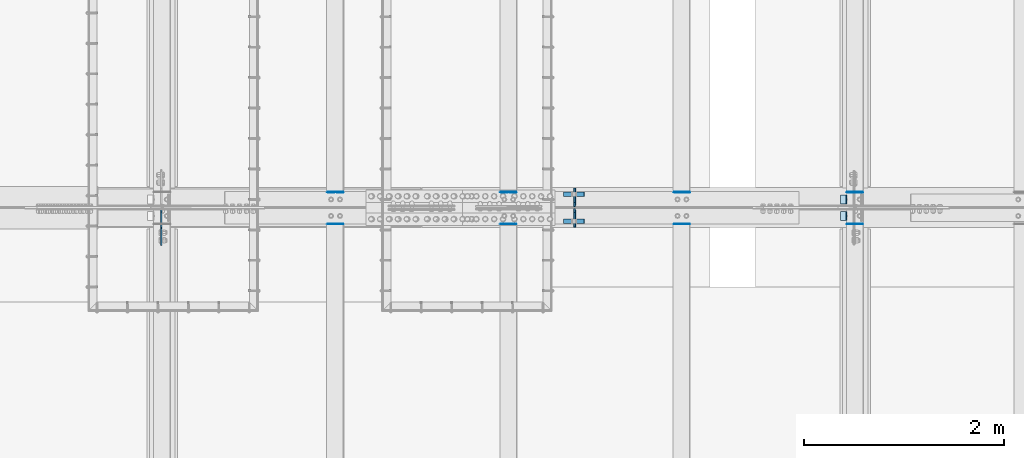
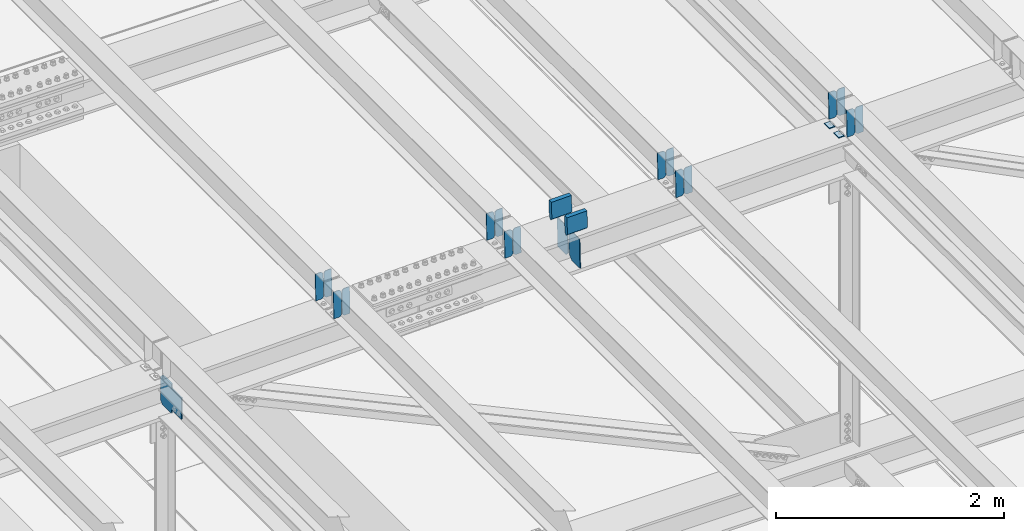
# One storey, part 3435 of 3843: 23 plates, 10 elements without a shape of their own.
"""IFC2X3 building model written with IfcOpenShell, lengths in millimetres."""

from ifc_helpers import new_model, si_unit, frame, origin_with_axes, place, context, subcontext, project, spatial, faceted_brep, material, type_object, element, aggregate, save


model = new_model("IFC2X3")

# Units and contexts
model_context = context("Model", 3, precision=1e-05, world=origin_with_axes())
body_context = subcontext(model_context, "Body", "Model", "MODEL_VIEW")
ifc_project = project(units=[si_unit("LENGTHUNIT", "METRE", prefix="MILLI"), si_unit("AREAUNIT", "SQUARE_METRE"), si_unit("VOLUMEUNIT", "CUBIC_METRE"), si_unit("MASSUNIT", "GRAM", prefix="KILO"), si_unit("TIMEUNIT", "SECOND"), si_unit("PLANEANGLEUNIT", "RADIAN"), si_unit("SOLIDANGLEUNIT", "STERADIAN"), si_unit("THERMODYNAMICTEMPERATUREUNIT", "DEGREE_CELSIUS"), si_unit("LUMINOUSINTENSITYUNIT", "LUMEN")], contexts=[model_context])

# Site, building, storey
site_placement = place(None, origin_with_axes())
site = spatial("IfcSite", under=ifc_project, at=site_placement, CompositionType="ELEMENT")
building_placement = place(site_placement, origin_with_axes())
building = spatial("IfcBuilding", under=site, at=building_placement, Name="Undefined", CompositionType="ELEMENT")
storey_placement = place(building_placement, origin_with_axes())
storey = spatial("IfcBuildingStorey", under=building, at=storey_placement, Name="Undefined", CompositionType="ELEMENT", Elevation=0.0)

# Assembly, plates
assembly_1_placement = place(storey_placement, origin_with_axes())
assembly_1 = element("IfcElementAssembly", 1, at=assembly_1_placement, inside=storey, Name="BEAM", AssemblyPlace="NOTDEFINED", PredefinedType="RIGID_FRAME")
ifc_material = material(Name="STEEL/A572-50")
plate_type_1 = type_object("IfcPlateType", PredefinedType="NOTDEFINED")
plate_1_placement = place(assembly_1_placement, frame((56013.0964783468, 67427.0111412027, 45923.0045844467), z_axis=(-0.0211520975519379, 0.00155378299993753, 0.999775061965211), x_axis=(-0.999776269354785, -3.22879999736168e-05, -0.0211520730074938)))
plate_1 = element("IfcPlate", 2, at=plate_1_placement, type_object=plate_type_1, material=ifc_material, Name="PLATE", context=body_context, shape_type="Brep", body=[
    faceted_brep([(0.0, -3.17499999999927, 0.0), (6.83940015733242e-10, -3.17499999996653, 288.924999998613), (6.54836185276508e-10, 3.17500000001746, 288.924999998591), (0.0, 3.17499999999927, 0.0), (60.3250007643655, -3.17500000017753, 288.924999998606), (60.3250007643219, 3.17499999979918, 288.924999998584), (79.3750000013097, -3.17500000025029, 269.875000761494), (79.375000001266, 3.17499999972642, 269.875000761487), (79.375000000713, -3.17500000026484, 19.0499992370605), (79.3750000006985, 3.17499999971187, 19.0499992370533), (60.325000763667, -3.17500000020664, -1.45519152283669e-11), (60.3250007636234, 3.17499999977736, -3.63797880709171e-11)], [[[0, 1, 2, 3]], [[1, 4, 5, 2]], [[4, 6, 7, 5]], [[6, 8, 9, 7]], [[8, 10, 11, 9]], [[10, 0, 3, 11]], [[5, 7, 9, 11, 3, 2]], [[10, 8, 6, 4, 1, 0]]]),
])
plate_2_placement = place(assembly_1_placement, frame((55927.3906576571, 67427.008323154, 45921.1913230356), z_axis=(-0.0211520975519379, 0.00155378299993753, 0.999775061965211), x_axis=(-0.999776269354785, -3.22879999736168e-05, -0.0211520730074938)))
plate_2 = element("IfcPlate", 3, at=plate_2_placement, type_object=plate_type_1, material=ifc_material, Name="PLATE", context=body_context, shape_type="Brep", body=[
    faceted_brep([(4.36557456851006e-11, -3.17499999998836, 19.0499992370969), (6.11180439591408e-10, -3.17499999996653, 269.875000761516), (5.96628524363041e-10, 3.17500000001746, 269.875000761502), (1.45519152283669e-11, 3.17499999998836, 19.0499992370824), (19.0499992376572, -3.17500000003201, 288.924999998606), (19.0499992376281, 3.1749999999447, 288.924999998584), (79.3750000013242, -3.17500000025029, 288.924999998591), (79.3750000013097, 3.1749999997337, 288.92499999857), (79.3750000006548, -3.17500000026484, -2.18278728425503e-11), (79.3750000006403, 3.17499999969732, -2.91038304567337e-11), (19.0499992370023, -3.17500000005384, 0.0), (19.0499992369587, 3.17499999992287, -1.45519152283669e-11)], [[[0, 1, 2, 3]], [[1, 4, 5, 2]], [[4, 6, 7, 5]], [[6, 8, 9, 7]], [[8, 10, 11, 9]], [[10, 0, 3, 11]], [[5, 7, 9, 11, 3, 2]], [[10, 8, 6, 4, 1, 0]]]),
])

assembly_2_placement = place(storey_placement, origin_with_axes())
assembly_2 = element("IfcElementAssembly", 4, at=assembly_2_placement, inside=storey, Name="BEAM", AssemblyPlace="NOTDEFINED", PredefinedType="RIGID_FRAME")
plate_3_placement = place(assembly_2_placement, frame((56013.0964783463, 67109.8915915396, 45923.2909467294), z_axis=(-0.0211520978350237, 0.000279663000066649, 0.999776230236438), x_axis=(-0.999776269348334, -6.33400000515396e-06, -0.0211520970073616)))
plate_3 = element("IfcPlate", 5, at=plate_3_placement, type_object=plate_type_1, material=ifc_material, Name="PLATE", context=body_context, shape_type="Brep", body=[
    faceted_brep([(0.0, -3.17499999999927, 0.0), (6.83940015733242e-10, -3.17499999996653, 288.924999998613), (6.54836185276508e-10, 3.17500000001746, 288.924999998591), (0.0, 3.17499999999927, 0.0), (60.3250007643655, -3.17500000017753, 288.924999998606), (60.3250007643219, 3.17499999979918, 288.924999998584), (79.3750000013097, -3.17500000025029, 269.875000761494), (79.375000001266, 3.17499999972642, 269.875000761487), (79.375000000713, -3.17500000026484, 19.0499992370605), (79.3750000006985, 3.17499999971187, 19.0499992370533), (60.325000763667, -3.17500000020664, -1.45519152283669e-11), (60.3250007636234, 3.17499999977736, -3.63797880709171e-11)], [[[0, 1, 2, 3]], [[1, 4, 5, 2]], [[4, 6, 7, 5]], [[6, 8, 9, 7]], [[8, 10, 11, 9]], [[10, 0, 3, 11]], [[5, 7, 9, 11, 3, 2]], [[10, 8, 6, 4, 1, 0]]]),
])
plate_4_placement = place(assembly_2_placement, frame((55927.3906576567, 67109.8910843224, 45921.4776831989), z_axis=(-0.0211520978350237, 0.000279663000066649, 0.999776230236438), x_axis=(-0.999776269348334, -6.33400000515396e-06, -0.0211520970073616)))
plate_4 = element("IfcPlate", 6, at=plate_4_placement, type_object=plate_type_1, material=ifc_material, Name="PLATE", context=body_context, shape_type="Brep", body=[
    faceted_brep([(4.36557456851006e-11, -3.17499999998836, 19.0499992370969), (6.11180439591408e-10, -3.17499999996653, 269.875000761516), (5.96628524363041e-10, 3.17500000001746, 269.875000761502), (1.45519152283669e-11, 3.17499999998836, 19.0499992370824), (19.0499992376572, -3.17500000003201, 288.924999998606), (19.0499992376281, 3.1749999999447, 288.924999998584), (79.3750000013242, -3.17500000025029, 288.924999998591), (79.3750000013097, 3.1749999997337, 288.92499999857), (79.3750000006548, -3.17500000026484, -2.18278728425503e-11), (79.3750000006403, 3.17499999969732, -2.91038304567337e-11), (19.0499992370023, -3.17500000005384, 0.0), (19.0499992369587, 3.17499999992287, -1.45519152283669e-11)], [[[0, 1, 2, 3]], [[1, 4, 5, 2]], [[4, 6, 7, 5]], [[6, 8, 9, 7]], [[8, 10, 11, 9]], [[10, 0, 3, 11]], [[5, 7, 9, 11, 3, 2]], [[10, 8, 6, 4, 1, 0]]]),
])

assembly_3_placement = place(storey_placement, origin_with_axes())
assembly_3 = element("IfcElementAssembly", 7, at=assembly_3_placement, inside=storey, Name="BEAM", AssemblyPlace="NOTDEFINED", PredefinedType="RIGID_FRAME")
plate_5_placement = place(assembly_3_placement, frame((54279.5464783245, 67427.0411486902, 45881.8611801861), z_axis=(-0.0211520983557567, 0.00145334399999411, 0.999775212998585), x_axis=(-0.999776269338764, -3.00889999762259e-05, -0.021152077007147)))
plate_5 = element("IfcPlate", 8, at=plate_5_placement, type_object=plate_type_1, material=ifc_material, Name="PLATE", context=body_context, shape_type="Brep", body=[
    faceted_brep([(0.0, -3.17499999999927, 0.0), (6.83940015733242e-10, -3.17499999996653, 288.924999998613), (6.54836185276508e-10, 3.17500000001746, 288.924999998591), (0.0, 3.17499999999927, 0.0), (60.3250007643655, -3.17500000017753, 288.924999998606), (60.3250007643219, 3.17499999979918, 288.924999998584), (79.3750000013097, -3.17500000025029, 269.875000761494), (79.375000001266, 3.17499999972642, 269.875000761487), (79.375000000713, -3.17500000026484, 19.0499992370605), (79.3750000006985, 3.17499999971187, 19.0499992370533), (60.325000763667, -3.17500000020664, -1.45519152283669e-11), (60.3250007636234, 3.17499999977736, -3.63797880709171e-11)], [[[0, 1, 2, 3]], [[1, 4, 5, 2]], [[4, 6, 7, 5]], [[6, 8, 9, 7]], [[8, 10, 11, 9]], [[10, 0, 3, 11]], [[5, 7, 9, 11, 3, 2]], [[10, 8, 6, 4, 1, 0]]]),
])
plate_6_placement = place(assembly_3_placement, frame((54193.8406576349, 67427.0385128048, 45880.0479185013), z_axis=(-0.0211520983557567, 0.00145334399999411, 0.999775212998585), x_axis=(-0.999776269338764, -3.00889999762259e-05, -0.021152077007147)))
plate_6 = element("IfcPlate", 9, at=plate_6_placement, type_object=plate_type_1, material=ifc_material, Name="PLATE", context=body_context, shape_type="Brep", body=[
    faceted_brep([(4.36557456851006e-11, -3.17499999998836, 19.0499992370969), (6.11180439591408e-10, -3.17499999996653, 269.875000761516), (5.96628524363041e-10, 3.17500000001746, 269.875000761502), (1.45519152283669e-11, 3.17499999998836, 19.0499992370824), (19.0499992376572, -3.17500000003201, 288.924999998606), (19.0499992376281, 3.1749999999447, 288.924999998584), (79.3750000013242, -3.17500000025029, 288.924999998591), (79.3750000013097, 3.1749999997337, 288.92499999857), (79.3750000006548, -3.17500000026484, -2.18278728425503e-11), (79.3750000006403, 3.17499999969732, -2.91038304567337e-11), (19.0499992370023, -3.17500000005384, 0.0), (19.0499992369587, 3.17499999992287, -1.45519152283669e-11)], [[[0, 1, 2, 3]], [[1, 4, 5, 2]], [[4, 6, 7, 5]], [[6, 8, 9, 7]], [[8, 10, 11, 9]], [[10, 0, 3, 11]], [[5, 7, 9, 11, 3, 2]], [[10, 8, 6, 4, 1, 0]]]),
])
aggregate(assembly_3, [plate_5, plate_6])

assembly_4_placement = place(storey_placement, origin_with_axes())
assembly_4 = element("IfcElementAssembly", 10, at=assembly_4_placement, inside=storey, Name="BEAM", AssemblyPlace="NOTDEFINED", PredefinedType="RIGID_FRAME")
plate_7_placement = place(assembly_4_placement, frame((54279.5464782984, 67109.8990383334, 45882.1279630658), z_axis=(-0.0211520976937244, 0.000254690999980084, 0.999776236912865), x_axis=(-0.999776269348334, -6.33400000515396e-06, -0.0211520970073616)))
plate_7 = element("IfcPlate", 11, at=plate_7_placement, type_object=plate_type_1, material=ifc_material, Name="PLATE", context=body_context, shape_type="Brep", body=[
    faceted_brep([(0.0, -3.17499999999927, 0.0), (6.83940015733242e-10, -3.17499999996653, 288.924999998613), (6.54836185276508e-10, 3.17500000001746, 288.924999998591), (0.0, 3.17499999999927, 0.0), (60.3250007643655, -3.17500000017753, 288.924999998606), (60.3250007643219, 3.17499999979918, 288.924999998584), (79.3750000013097, -3.17500000025029, 269.875000761494), (79.375000001266, 3.17499999972642, 269.875000761487), (79.375000000713, -3.17500000026484, 19.0499992370605), (79.3750000006985, 3.17499999971187, 19.0499992370533), (60.325000763667, -3.17500000020664, -1.45519152283669e-11), (60.3250007636234, 3.17499999977736, -3.63797880709171e-11)], [[[0, 1, 2, 3]], [[1, 4, 5, 2]], [[4, 6, 7, 5]], [[6, 8, 9, 7]], [[8, 10, 11, 9]], [[10, 0, 3, 11]], [[5, 7, 9, 11, 3, 2]], [[10, 8, 6, 4, 1, 0]]]),
])
plate_8_placement = place(assembly_4_placement, frame((54193.8406576091, 67109.8985764075, 45880.3146995236), z_axis=(-0.0211520976937244, 0.000254690999980084, 0.999776236912865), x_axis=(-0.999776269348334, -6.33400000515396e-06, -0.0211520970073616)))
plate_8 = element("IfcPlate", 12, at=plate_8_placement, type_object=plate_type_1, material=ifc_material, Name="PLATE", context=body_context, shape_type="Brep", body=[
    faceted_brep([(4.36557456851006e-11, -3.17499999998836, 19.0499992370969), (6.11180439591408e-10, -3.17499999996653, 269.875000761516), (5.96628524363041e-10, 3.17500000001746, 269.875000761502), (1.45519152283669e-11, 3.17499999998836, 19.0499992370824), (19.0499992376572, -3.17500000003201, 288.924999998606), (19.0499992376281, 3.1749999999447, 288.924999998584), (79.3750000013242, -3.17500000025029, 288.924999998591), (79.3750000013097, 3.1749999997337, 288.92499999857), (79.3750000006548, -3.17500000026484, -2.18278728425503e-11), (79.3750000006403, 3.17499999969732, -2.91038304567337e-11), (19.0499992370023, -3.17500000005384, 0.0), (19.0499992369587, 3.17499999992287, -1.45519152283669e-11)], [[[0, 1, 2, 3]], [[1, 4, 5, 2]], [[4, 6, 7, 5]], [[6, 8, 9, 7]], [[8, 10, 11, 9]], [[10, 0, 3, 11]], [[5, 7, 9, 11, 3, 2]], [[10, 8, 6, 4, 1, 0]]]),
])
aggregate(assembly_4, [plate_7, plate_8])

assembly_5_placement = place(storey_placement, origin_with_axes())
assembly_5 = element("IfcElementAssembly", 13, at=assembly_5_placement, inside=storey, Name="BEAM", AssemblyPlace="NOTDEFINED", PredefinedType="RIGID_FRAME")
plate_9_placement = place(assembly_5_placement, frame((52545.9966584462, 67427.0735193334, 45840.1237570068), z_axis=(-0.0211520981778377, 0.00134498899952451, 0.999775364643111), x_axis=(-0.999776269352834, -2.81529999742652e-05, -0.0211520790074793)))
plate_9 = element("IfcPlate", 14, at=plate_9_placement, type_object=plate_type_1, material=ifc_material, Name="PLATE", context=body_context, shape_type="Brep", body=[
    faceted_brep([(0.0, -3.17499999999927, 0.0), (6.83940015733242e-10, -3.17499999996653, 288.924999998613), (6.54836185276508e-10, 3.17500000001746, 288.924999998591), (0.0, 3.17499999999927, 0.0), (60.3250007643655, -3.17500000017753, 288.924999998606), (60.3250007643219, 3.17499999979918, 288.924999998584), (79.3750000013097, -3.17500000025029, 269.875000761494), (79.375000001266, 3.17499999972642, 269.875000761487), (79.375000000713, -3.17500000026484, 19.0499992370605), (79.3750000006985, 3.17499999971187, 19.0499992370533), (60.325000763667, -3.17500000020664, -1.45519152283669e-11), (60.3250007636234, 3.17499999977736, -3.63797880709171e-11)], [[[0, 1, 2, 3]], [[1, 4, 5, 2]], [[4, 6, 7, 5]], [[6, 8, 9, 7]], [[8, 10, 11, 9]], [[10, 0, 3, 11]], [[5, 7, 9, 11, 3, 2]], [[10, 8, 6, 4, 1, 0]]]),
])
plate_10_placement = place(assembly_5_placement, frame((52460.2908377569, 67427.0710780809, 45838.3104950502), z_axis=(-0.0211520981778377, 0.00134498899952451, 0.999775364643111), x_axis=(-0.999776269352834, -2.81529999742652e-05, -0.0211520790074793)))
plate_10 = element("IfcPlate", 15, at=plate_10_placement, type_object=plate_type_1, material=ifc_material, Name="PLATE", context=body_context, shape_type="Brep", body=[
    faceted_brep([(4.36557456851006e-11, -3.17499999998836, 19.0499992370969), (6.11180439591408e-10, -3.17499999996653, 269.875000761516), (5.96628524363041e-10, 3.17500000001746, 269.875000761502), (1.45519152283669e-11, 3.17499999998836, 19.0499992370824), (19.0499992376572, -3.17500000003201, 288.924999998606), (19.0499992376281, 3.1749999999447, 288.924999998584), (79.3750000013242, -3.17500000025029, 288.924999998591), (79.3750000013097, 3.1749999997337, 288.92499999857), (79.3750000006548, -3.17500000026484, -2.18278728425503e-11), (79.3750000006403, 3.17499999969732, -2.91038304567337e-11), (19.0499992370023, -3.17500000005384, 0.0), (19.0499992369587, 3.17499999992287, -1.45519152283669e-11)], [[[0, 1, 2, 3]], [[1, 4, 5, 2]], [[4, 6, 7, 5]], [[6, 8, 9, 7]], [[8, 10, 11, 9]], [[10, 0, 3, 11]], [[5, 7, 9, 11, 3, 2]], [[10, 8, 6, 4, 1, 0]]]),
])
aggregate(assembly_5, [plate_9, plate_10])

assembly_6_placement = place(storey_placement, origin_with_axes())
assembly_6 = element("IfcElementAssembly", 16, at=assembly_6_placement, inside=storey, Name="BEAM", AssemblyPlace="NOTDEFINED", PredefinedType="RIGID_FRAME")
plate_11_placement = place(assembly_6_placement, frame((52545.9966620954, 67109.907216579, 45840.3697196294), z_axis=(-0.0211520975606108, 0.000229718999995384, 0.999776242965378), x_axis=(-0.999776269357106, -4.75100003261494e-06, -0.0211520970075272)))
plate_11 = element("IfcPlate", 17, at=plate_11_placement, type_object=plate_type_1, material=ifc_material, Name="PLATE", context=body_context, shape_type="Brep", body=[
    faceted_brep([(0.0, -3.17499999999927, 0.0), (6.83940015733242e-10, -3.17499999996653, 288.924999998613), (6.54836185276508e-10, 3.17500000001746, 288.924999998591), (0.0, 3.17499999999927, 0.0), (60.3250007643655, -3.17500000017753, 288.924999998606), (60.3250007643219, 3.17499999979918, 288.924999998584), (79.3750000013097, -3.17500000025029, 269.875000761494), (79.375000001266, 3.17499999972642, 269.875000761487), (79.375000000713, -3.17500000026484, 19.0499992370605), (79.3750000006985, 3.17499999971187, 19.0499992370533), (60.325000763667, -3.17500000020664, -1.45519152283669e-11), (60.3250007636234, 3.17499999977736, -3.63797880709171e-11)], [[[0, 1, 2, 3]], [[1, 4, 5, 2]], [[4, 6, 7, 5]], [[6, 8, 9, 7]], [[8, 10, 11, 9]], [[10, 0, 3, 11]], [[5, 7, 9, 11, 3, 2]], [[10, 8, 6, 4, 1, 0]]]),
])
plate_12_placement = place(assembly_6_placement, frame((52460.2908414061, 67109.9068019173, 45838.5564560757), z_axis=(-0.0211520975606108, 0.000229718999995384, 0.999776242965378), x_axis=(-0.999776269357106, -4.75100003261494e-06, -0.0211520970075272)))
plate_12 = element("IfcPlate", 18, at=plate_12_placement, type_object=plate_type_1, material=ifc_material, Name="PLATE", context=body_context, shape_type="Brep", body=[
    faceted_brep([(4.36557456851006e-11, -3.17499999998836, 19.0499992370969), (6.11180439591408e-10, -3.17499999996653, 269.875000761516), (5.96628524363041e-10, 3.17500000001746, 269.875000761502), (1.45519152283669e-11, 3.17499999998836, 19.0499992370824), (19.0499992376572, -3.17500000003201, 288.924999998606), (19.0499992376281, 3.1749999999447, 288.924999998584), (79.3750000013242, -3.17500000025029, 288.924999998591), (79.3750000013097, 3.1749999997337, 288.92499999857), (79.3750000006548, -3.17500000026484, -2.18278728425503e-11), (79.3750000006403, 3.17499999969732, -2.91038304567337e-11), (19.0499992370023, -3.17500000005384, 0.0), (19.0499992369587, 3.17499999992287, -1.45519152283669e-11)], [[[0, 1, 2, 3]], [[1, 4, 5, 2]], [[4, 6, 7, 5]], [[6, 8, 9, 7]], [[8, 10, 11, 9]], [[10, 0, 3, 11]], [[5, 7, 9, 11, 3, 2]], [[10, 8, 6, 4, 1, 0]]]),
])
aggregate(assembly_6, [plate_11, plate_12])

assembly_7_placement = place(storey_placement, origin_with_axes())
assembly_7 = element("IfcElementAssembly", 19, at=assembly_7_placement, inside=storey, Name="BEAM", AssemblyPlace="NOTDEFINED", PredefinedType="RIGID_FRAME")
plate_13_placement = place(assembly_7_placement, frame((50812.4464826768, 67427.1097663836, 45797.8291006045), z_axis=(-0.0211520978152839, 0.00122362399946723, 0.99977552055565), x_axis=(-0.999776269341983, -2.62180000434616e-05, -0.0211520820072761)))
plate_13 = element("IfcPlate", 20, at=plate_13_placement, type_object=plate_type_1, material=ifc_material, Name="PLATE", context=body_context, shape_type="Brep", body=[
    faceted_brep([(0.0, -3.17499999999927, 0.0), (6.83940015733242e-10, -3.17499999996653, 288.924999998613), (6.54836185276508e-10, 3.17500000001746, 288.924999998591), (0.0, 3.17499999999927, 0.0), (60.3250007643655, -3.17500000017753, 288.924999998606), (60.3250007643219, 3.17499999979918, 288.924999998584), (79.3750000013097, -3.17500000025029, 269.875000761494), (79.375000001266, 3.17499999972642, 269.875000761487), (79.375000000713, -3.17500000026484, 19.0499992370605), (79.3750000006985, 3.17499999971187, 19.0499992370533), (60.325000763667, -3.17500000020664, -1.45519152283669e-11), (60.3250007636234, 3.17499999977736, -3.63797880709171e-11)], [[[0, 1, 2, 3]], [[1, 4, 5, 2]], [[4, 6, 7, 5]], [[6, 8, 9, 7]], [[8, 10, 11, 9]], [[10, 0, 3, 11]], [[5, 7, 9, 11, 3, 2]], [[10, 8, 6, 4, 1, 0]]]),
])
plate_14_placement = place(assembly_7_placement, frame((50726.7406619871, 67427.1075495334, 45796.0158383596), z_axis=(-0.0211520978152839, 0.00122362399946723, 0.99977552055565), x_axis=(-0.999776269341983, -2.62180000434616e-05, -0.0211520820072761)))
plate_14 = element("IfcPlate", 21, at=plate_14_placement, type_object=plate_type_1, material=ifc_material, Name="PLATE", context=body_context, shape_type="Brep", body=[
    faceted_brep([(4.36557456851006e-11, -3.17499999998836, 19.0499992370969), (6.11180439591408e-10, -3.17499999996653, 269.875000761516), (5.96628524363041e-10, 3.17500000001746, 269.875000761502), (1.45519152283669e-11, 3.17499999998836, 19.0499992370824), (19.0499992376572, -3.17500000003201, 288.924999998606), (19.0499992376281, 3.1749999999447, 288.924999998584), (79.3750000013242, -3.17500000025029, 288.924999998591), (79.3750000013097, 3.1749999997337, 288.92499999857), (79.3750000006548, -3.17500000026484, -2.18278728425503e-11), (79.3750000006403, 3.17499999969732, -2.91038304567337e-11), (19.0499992370023, -3.17500000005384, 0.0), (19.0499992369587, 3.17499999992287, -1.45519152283669e-11)], [[[0, 1, 2, 3]], [[1, 4, 5, 2]], [[4, 6, 7, 5]], [[6, 8, 9, 7]], [[8, 10, 11, 9]], [[10, 0, 3, 11]], [[5, 7, 9, 11, 3, 2]], [[10, 8, 6, 4, 1, 0]]]),
])
aggregate(assembly_7, [plate_13, plate_14])

assembly_8_placement = place(storey_placement, origin_with_axes())
assembly_8 = element("IfcElementAssembly", 22, at=assembly_8_placement, inside=storey, Name="BEAM", AssemblyPlace="NOTDEFINED", PredefinedType="RIGID_FRAME")
plate_15_placement = place(assembly_8_placement, frame((50812.446481825, 67109.9120676337, 45798.0532415268), z_axis=(-0.0211520984779636, 0.000211000000017521, 0.999776247071803), x_axis=(-0.999776269357106, -4.75100003261494e-06, -0.0211520970075272)))
plate_15 = element("IfcPlate", 23, at=plate_15_placement, type_object=plate_type_1, material=ifc_material, Name="PLATE", context=body_context, shape_type="Brep", body=[
    faceted_brep([(0.0, -3.17499999999927, 0.0), (6.83940015733242e-10, -3.17499999996653, 288.924999998613), (6.54836185276508e-10, 3.17500000001746, 288.924999998591), (0.0, 3.17499999999927, 0.0), (60.3250007643655, -3.17500000017753, 288.924999998606), (60.3250007643219, 3.17499999979918, 288.924999998584), (79.3750000013097, -3.17500000025029, 269.875000761494), (79.375000001266, 3.17499999972642, 269.875000761487), (79.375000000713, -3.17500000026484, 19.0499992370605), (79.3750000006985, 3.17499999971187, 19.0499992370533), (60.325000763667, -3.17500000020664, -1.45519152283669e-11), (60.3250007636234, 3.17499999977736, -3.63797880709171e-11)], [[[0, 1, 2, 3]], [[1, 4, 5, 2]], [[4, 6, 7, 5]], [[6, 8, 9, 7]], [[8, 10, 11, 9]], [[10, 0, 3, 11]], [[5, 7, 9, 11, 3, 2]], [[10, 8, 6, 4, 1, 0]]]),
])
plate_16_placement = place(assembly_8_placement, frame((50726.7406611357, 67109.9116850356, 45796.2399779666), z_axis=(-0.0211520984779636, 0.000211000000017521, 0.999776247071803), x_axis=(-0.999776269357106, -4.75100003261494e-06, -0.0211520970075272)))
plate_16 = element("IfcPlate", 24, at=plate_16_placement, type_object=plate_type_1, material=ifc_material, Name="PLATE", context=body_context, shape_type="Brep", body=[
    faceted_brep([(4.36557456851006e-11, -3.17499999998836, 19.0499992370969), (6.11180439591408e-10, -3.17499999996653, 269.875000761516), (5.96628524363041e-10, 3.17500000001746, 269.875000761502), (1.45519152283669e-11, 3.17499999998836, 19.0499992370824), (19.0499992376572, -3.17500000003201, 288.924999998606), (19.0499992376281, 3.1749999999447, 288.924999998584), (79.3750000013242, -3.17500000025029, 288.924999998591), (79.3750000013097, 3.1749999997337, 288.92499999857), (79.3750000006548, -3.17500000026484, -2.18278728425503e-11), (79.3750000006403, 3.17499999969732, -2.91038304567337e-11), (19.0499992370023, -3.17500000005384, 0.0), (19.0499992369587, 3.17499999992287, -1.45519152283669e-11)], [[[0, 1, 2, 3]], [[1, 4, 5, 2]], [[4, 6, 7, 5]], [[6, 8, 9, 7]], [[8, 10, 11, 9]], [[10, 0, 3, 11]], [[5, 7, 9, 11, 3, 2]], [[10, 8, 6, 4, 1, 0]]]),
])
aggregate(assembly_8, [plate_15, plate_16])

assembly_9_placement = place(storey_placement, origin_with_axes())
assembly_9 = element("IfcElementAssembly", 25, at=assembly_9_placement, inside=storey, Name="BEAM", AssemblyPlace="NOTDEFINED", PredefinedType="RIGID_FRAME")
plate_type_2 = type_object("IfcPlateType", PredefinedType="NOTDEFINED")
plate_17_placement = place(assembly_9_placement, frame((53127.4269737667, 67076.3375, 45488.1500430333), z_axis=(-0.0230720240097944, 0.0, 0.99973380542427), x_axis=(0.0, 1.0, 0.0)))
plate_17 = element("IfcPlate", 26, at=plate_17_placement, type_object=plate_type_2, material=ifc_material, Name="PL", context=body_context, shape_type="Brep", body=[
    faceted_brep([(0.0, -4.76249999999709, 0.0), (0.0, -4.76249999986612, 316.893560966142), (0.0, 4.7625000000844, 316.893560966142), (0.0, 4.76249999999709, 0.0), (145.746763610834, -4.76249999986612, 316.893560966142), (145.746763610834, 4.7625000000844, 316.893560966142), (184.149999999994, -4.76249999989523, 278.490324577106), (184.149999999994, 4.76250000006985, 278.490324577098), (184.149999999994, -4.76249999999709, 38.4032363890365), (184.149999999994, 4.76249999998254, 38.4032363890365), (145.746763610834, -4.76250000001164, 7.27595761418343e-12), (145.746763610834, 4.76249999995343, 0.0)], [[[0, 1, 2, 3]], [[1, 4, 5, 2]], [[4, 6, 7, 5]], [[6, 8, 9, 7]], [[8, 10, 11, 9]], [[10, 0, 3, 11]], [[5, 7, 9, 11, 3, 2]], [[10, 8, 6, 4, 1, 0]]]),
])
plate_18_placement = place(assembly_9_placement, frame((53127.4269737667, 67283.3125, 45488.1500430333), z_axis=(-0.0230720240097944, 0.0, 0.99973380542427), x_axis=(0.0, 1.0, 0.0)))
plate_18 = element("IfcPlate", 27, at=plate_18_placement, type_object=plate_type_2, material=ifc_material, Name="PL", context=body_context, shape_type="Brep", body=[
    faceted_brep([(0.0, -4.76249999999709, 38.4032363890365), (0.0, -4.76249999989523, 278.490324577106), (0.0, 4.76250000006985, 278.490324577098), (0.0, 4.76249999998254, 38.4032363890365), (38.4032363891602, -4.76249999986612, 316.893560966142), (38.4032363891602, 4.7625000000844, 316.893560966142), (184.149999999994, -4.76249999986612, 316.893560966142), (184.149999999994, 4.7625000000844, 316.893560966142), (184.150000000009, -4.76249999999709, 0.0), (184.150000000009, 4.76249999999709, 0.0), (38.4032363891602, -4.76250000001164, 7.27595761418343e-12), (38.4032363891602, 4.76249999995343, 0.0)], [[[0, 1, 2, 3]], [[1, 4, 5, 2]], [[4, 6, 7, 5]], [[6, 8, 9, 7]], [[8, 10, 11, 9]], [[10, 0, 3, 11]], [[5, 7, 9, 11, 3, 2]], [[10, 8, 6, 4, 1, 0]]]),
])
plate_type_3 = type_object("IfcPlateType", PredefinedType="NOTDEFINED")
plate_19_placement = place(assembly_9_placement, frame((53012.7839450749, 67408.028125, 46046.1887802061), z_axis=(0.0217666070074993, 0.0, -0.999763079343992), x_axis=(0.999763079343992, 0.0, 0.0217666070075027)))
plate_19 = element("IfcPlate", 28, at=plate_19_placement, type_object=plate_type_3, material=ifc_material, Name="PLATE", context=body_context, shape_type="Brep", body=[
    faceted_brep([(203.200005058941, -22.2250000000058, -1.16415321826935e-10), (7.27595761418343e-12, -22.2250000000058, -7.27595761418343e-12), (7.27595761418343e-12, 22.2250000000058, -7.27595761418343e-12), (203.200005058941, 22.2250000000058, -1.16415321826935e-10), (203.838531807472, -22.2250000000058, 0.00187068080413155), (203.838531807472, 22.2250000000058, 0.00187068080413155), (203.310341304641, -22.2250000000058, 180.861817383484), (0.04046799018397, -22.2250000000058, 180.907287948779), (203.245434494536, 0.0133131837355904, 203.086833080139), (0.0454396034692763, 0.0133129994646879, 203.132287829787), (0.0404679902494536, 22.2250000000058, 180.907288225317), (203.310341303353, 22.2250000000058, 180.861817822159)], [[[0, 1, 2, 3]], [[4, 0, 3, 5]], [[1, 0, 4, 6, 7]], [[7, 6, 8, 9]], [[2, 1, 7, 9, 10]], [[5, 3, 2, 10, 11]], [[6, 4, 5, 11, 8]], [[10, 9, 8, 11]]]),
])
plate_20_placement = place(assembly_9_placement, frame((53012.7839450749, 67134.978125, 46046.1887802061), z_axis=(0.0217666070074993, 0.0, -0.999763079343992), x_axis=(0.999763079343992, 0.0, 0.0217666070075027)))
plate_20 = element("IfcPlate", 29, at=plate_20_placement, type_object=plate_type_3, material=ifc_material, Name="PLATE", context=body_context, shape_type="Brep", body=[
    faceted_brep([(203.200005058941, -22.2250000000058, -1.16415321826935e-10), (7.27595761418343e-12, -22.2250000000058, -7.27595761418343e-12), (7.27595761418343e-12, 22.2250000000058, -7.27595761418343e-12), (203.200005058941, 22.2250000000058, -1.16415321826935e-10), (203.838531807472, -22.2250000000058, 0.00187068080413155), (203.838531807472, 22.2250000000058, 0.00187068080413155), (203.310341304641, -22.2250000000058, 180.861817383484), (0.04046799018397, -22.2250000000058, 180.907287948779), (203.245434494536, 0.0133131837355904, 203.086833080139), (0.0454396034692763, 0.0133129994646879, 203.132287829787), (0.0404679902494536, 22.2250000000058, 180.907288225317), (203.310341303353, 22.2250000000058, 180.861817822159)], [[[0, 1, 2, 3]], [[4, 0, 3, 5]], [[1, 0, 4, 6, 7]], [[7, 6, 8, 9]], [[2, 1, 7, 9, 10]], [[5, 3, 2, 10, 11]], [[6, 4, 5, 11, 8]], [[10, 9, 8, 11]]]),
])
aggregate(assembly_9, [plate_19, plate_20, plate_17, plate_18])

# Plate
plate_type_4 = type_object("IfcPlateType", PredefinedType="NOTDEFINED")
plate_21_placement = place(assembly_1_placement, frame((55848.1677281253, 67398.8999999999, 45913.4050314605), z_axis=(0.0, -1.0, 0.0), x_axis=(-0.999776270257024, 0.0, -0.0211520550054595)))
plate_21 = element("IfcPlate", 30, at=plate_21_placement, type_object=plate_type_4, material=ifc_material, Name="PLATE", context=body_context, shape_type="Brep", body=[
    faceted_brep([(9.52499999982683, -4.7625000001135, 88.8999999999942), (0.0, 4.76249999999709, 88.9000015258789), (0.0, 4.76249999999709, 0.0), (9.52499999981956, -4.76249999999709, 0.0), (63.4999984608512, -4.76249999988795, 88.8999999999796), (63.4999984608367, -4.76249999988795, -1.45519152283669e-11), (63.4999984608221, 4.76250000013533, -1.45519152283669e-11), (63.4999984608367, 4.76250000013533, 88.8999999999796)], [[[0, 1, 2, 3]], [[4, 5, 6, 7]], [[5, 4, 0, 3]], [[6, 5, 3, 2]], [[7, 6, 2, 1]], [[4, 7, 1, 0]]]),
])

aggregate(assembly_1, [plate_1, plate_2, plate_21])

plate_22_placement = place(assembly_2_placement, frame((55848.1677281253, 67233.8000015258, 45913.4050314605), z_axis=(0.0, -1.0, 0.0), x_axis=(-0.999776270257024, 0.0, -0.0211520550054595)))
plate_22 = element("IfcPlate", 31, at=plate_22_placement, type_object=plate_type_4, material=ifc_material, Name="PLATE", context=body_context, shape_type="Brep", body=[
    faceted_brep([(9.52499999982683, -4.7625000001135, 88.8999999999942), (0.0, 4.76249999999709, 88.9000015258789), (0.0, 4.76249999999709, 0.0), (9.52499999981956, -4.76249999999709, 0.0), (63.4999984608512, -4.76249999988795, 88.8999999999796), (63.4999984608367, -4.76249999988795, -1.45519152283669e-11), (63.4999984608221, 4.76250000013533, -1.45519152283669e-11), (63.4999984608367, 4.76250000013533, 88.8999999999796)], [[[0, 1, 2, 3]], [[4, 5, 6, 7]], [[5, 4, 0, 3]], [[6, 5, 3, 2]], [[7, 6, 2, 1]], [[4, 7, 1, 0]]]),
])

aggregate(assembly_2, [plate_3, plate_4, plate_22])

# Assembly, plate
assembly_10_placement = place(storey_placement, origin_with_axes())
assembly_10 = element("IfcElementAssembly", 32, at=assembly_10_placement, inside=storey, Name="BEAM", AssemblyPlace="NOTDEFINED", PredefinedType="RIGID_FRAME")
plate_type_5 = type_object("IfcPlateType", PredefinedType="NOTDEFINED")
plate_23_placement = place(assembly_10_placement, frame((48985.4875705276, 67260.787499912, 45418.2186269619), z_axis=(0.0, -0.707106781186682, 0.707106781186413), x_axis=(0.0, -0.707106781186548, -0.707106781186548)))
plate_23 = element("IfcPlate", 33, at=plate_23_placement, type_object=plate_type_5, material=ifc_material, Name="PLATE", context=body_context, shape_type="Brep", body=[
    faceted_brep([(0.0, -6.3499999046162, 0.0), (-179.451426902579, -6.34999999999854, 179.451426902888), (-179.451426902579, 6.34999999999854, 179.451426902888), (7.27595761418343e-12, 6.3499999046162, 0.0), (-179.451426902531, -6.34999999999854, 224.352707508471), (-179.451426902531, 6.34999999999854, 224.352707508471), (-68.320757394682, -6.34999999999854, 335.483377017285), (-68.320757394682, 6.34999999999854, 335.483377017285), (-46.1747610570455, -6.34999999999854, 313.337380695964), (-46.1747610570455, 6.34999999999854, 313.337380695964), (-42.0545845888846, -6.34999999999854, 310.584366795505), (-42.0545845888846, 6.34999999999854, 310.584366795505), (-37.1945050708309, -6.34999999999854, 309.617636872936), (-37.1945050708309, 6.34999999999854, 309.617636872936), (-32.3344255527772, -6.34999999999854, 310.584366795556), (-32.3344255527772, 6.34999999999854, 310.584366795556), (-28.2142490845872, -6.34999999999854, 313.337380696059), (-28.2142490845872, 6.34999999999854, 313.337380696059), (88.5290806096309, -6.34999999999854, 430.080710390277), (88.5290806096309, 6.34999999999854, 430.080710390277), (250.173690788099, -6.34999999999854, 268.436100211809), (250.173690788099, 6.34999999999854, 268.436100211809), (133.43036109388, -6.34999999999854, 151.692770517591), (133.43036109388, 6.34999999999854, 151.692770517591), (130.67734719337, -6.34999999999854, 147.572594049416), (130.67734719337, 6.34999999999854, 147.572594049416), (129.710617270757, -6.34999999999854, 142.712514531348), (129.710617270757, 6.34999999999854, 142.712514531348), (130.677347193327, -6.34999999999854, 137.852435013294), (130.677347193327, 6.34999999999854, 137.852435013294), (133.430361093779, -6.34999999999854, 133.73225854514), (133.430361093779, 6.34999999999854, 133.73225854514), (156.031950102829, -6.35000000000582, 111.130669497703), (156.031950102829, 6.35000000000582, 111.130669497703), (44.9012806051323, -6.35000000000582, -1.45519152283669e-11), (44.9012806051323, 6.35000000000582, -1.45519152283669e-11)], [[[0, 1, 2, 3]], [[1, 4, 5, 2]], [[4, 6, 7, 5]], [[6, 8, 9, 7]], [[8, 10, 11, 9]], [[10, 12, 13, 11]], [[12, 14, 15, 13]], [[14, 16, 17, 15]], [[16, 18, 19, 17]], [[18, 20, 21, 19]], [[20, 22, 23, 21]], [[22, 24, 25, 23]], [[24, 26, 27, 25]], [[26, 28, 29, 27]], [[28, 30, 31, 29]], [[30, 32, 33, 31]], [[32, 34, 35, 33]], [[34, 0, 3, 35]], [[5, 7, 9, 11, 13, 15, 17, 19, 21, 23, 25, 27, 29, 31, 33, 35, 3, 2]], [[34, 32, 30, 28, 26, 24, 22, 20, 18, 16, 14, 12, 10, 8, 6, 4, 1, 0]]]),
])
aggregate(assembly_10, [plate_23])

save(model, "model.ifc")
